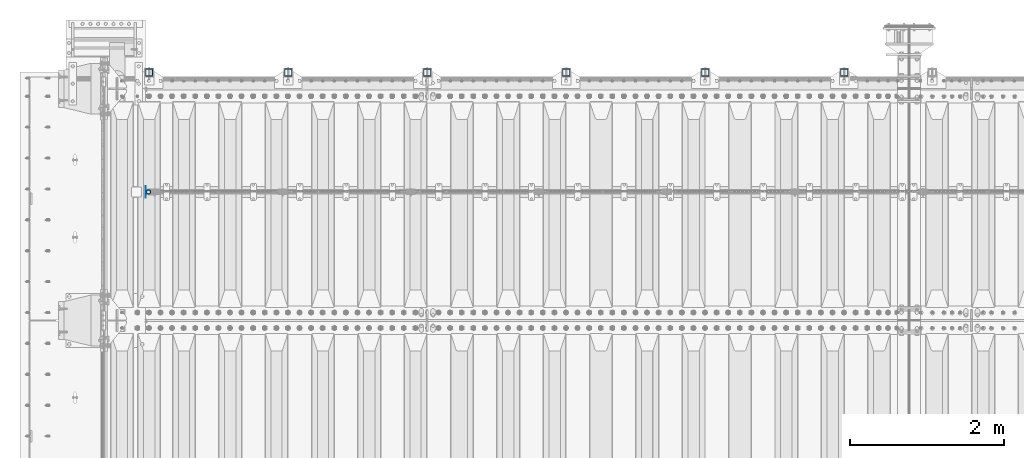
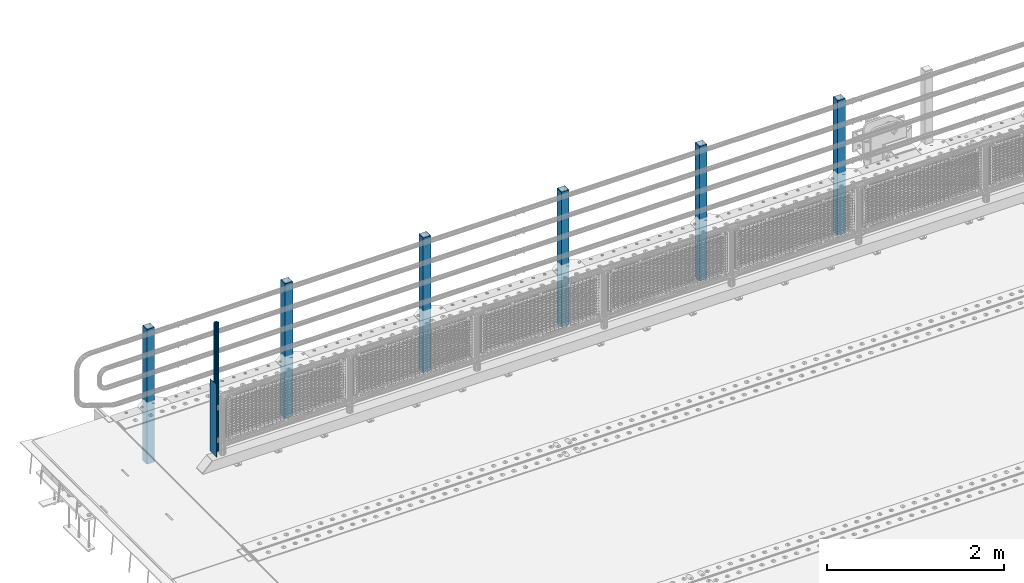
# One storey, part 60 of 219: 8 columns.
"""IFC2X3 building model written with IfcOpenShell, lengths in millimetres."""

from ifc_helpers import new_model, si_unit, frame, origin_with_axes, place, context, subcontext, project, spatial, faceted_brep, material, type_object, element, save


model = new_model("IFC2X3")

# Units and contexts
model_context = context("Model", 3, precision=1e-05, world=origin_with_axes())
body_context = subcontext(model_context, "Body", "Model", "MODEL_VIEW")
ifc_project = project(units=[si_unit("LENGTHUNIT", "METRE", prefix="MILLI"), si_unit("AREAUNIT", "SQUARE_METRE"), si_unit("VOLUMEUNIT", "CUBIC_METRE"), si_unit("MASSUNIT", "GRAM", prefix="KILO"), si_unit("TIMEUNIT", "SECOND"), si_unit("PLANEANGLEUNIT", "RADIAN"), si_unit("SOLIDANGLEUNIT", "STERADIAN"), si_unit("THERMODYNAMICTEMPERATUREUNIT", "DEGREE_CELSIUS"), si_unit("LUMINOUSINTENSITYUNIT", "LUMEN")], contexts=[model_context])

# Site, building, storey
site_placement = place(None, origin_with_axes())
site = spatial("IfcSite", under=ifc_project, at=site_placement, CompositionType="ELEMENT")
building_placement = place(site_placement, origin_with_axes())
building = spatial("IfcBuilding", under=site, at=building_placement, Name="Standard", CompositionType="ELEMENT")
storey_placement = place(building_placement, origin_with_axes())
storey = spatial("IfcBuildingStorey", under=building, at=storey_placement, Name="Undefined", CompositionType="ELEMENT", Elevation=0.0)

# Columns
ifc_material_1 = material(Name="Misc_Undefined")
column_type_1 = type_object("IfcColumnType", PredefinedType="NOTDEFINED")
column_1_placement = place(storey_placement, frame((541.0, 31664.5, 238.02), z_axis=(1.0, 0.0, 0.0), x_axis=(0.0, 0.0, 1.0)))
element("IfcColumn", 1, at=column_1_placement, inside=storey, type_object=column_type_1, material=ifc_material_1, context=body_context, shape_type="Brep", body=[
    faceted_brep([(0.0, -25.3499999999985, 0.0), (0.0, -23.4203461491597, 9.70102501045585), (1761.98, -23.4203461491597, 9.70102501045585), (1761.98, -25.3499999999985, 0.0), (0.0, -17.9251569030785, 17.9251569030785), (1761.98, -17.9251569030785, 17.9251569030785), (0.0, -9.70102501045403, 23.4203461491616), (1761.98, -9.70102501045403, 23.4203461491616), (0.0, 0.0, 25.3500000000004), (1761.98, 0.0, 25.3500000000004), (0.0, 9.70102501045403, 23.4203461491616), (1761.98, 9.70102501045403, 23.4203461491616), (0.0, 17.9251569030785, 17.9251569030785), (1761.98, 17.9251569030785, 17.9251569030785), (0.0, 23.4203461491597, 9.70102501045585), (1761.98, 23.4203461491597, 9.70102501045585), (0.0, 25.3499999999985, 0.0), (1761.98, 25.3499999999985, 0.0), (0.0, 23.4203461491597, -9.70102501045585), (1761.98, 23.4203461491597, -9.70102501045585), (0.0, 17.9251569030785, -17.9251569030785), (1761.98, 17.9251569030785, -17.9251569030785), (0.0, 9.70102501045403, -23.4203461491616), (1761.98, 9.70102501045403, -23.4203461491616), (0.0, 0.0, -25.3500000000004), (1761.98, 0.0, -25.3500000000004), (0.0, -9.70102501045403, -23.4203461491616), (1761.98, -9.70102501045403, -23.4203461491616), (0.0, -17.9251569030785, -17.9251569030785), (1761.98, -17.9251569030785, -17.9251569030785), (0.0, -23.4203461491597, -9.70102501045585), (1761.98, -23.4203461491597, -9.70102501045585), (0.0, -30.1500000000015, 0.0), (0.0, -27.8549679052157, -11.5379054858076), (1761.98, -27.8549679052157, -11.5379054858076), (1761.98, -30.1500000000015, 0.0), (0.0, -21.3192694527752, -21.3192694527752), (1761.98, -21.3192694527752, -21.3192694527752), (0.0, -11.5379054858058, -27.8549679052157), (1761.98, -11.5379054858058, -27.8549679052157), (0.0, 0.0, -30.1499999999996), (1761.98, 0.0, -30.1499999999996), (0.0, 11.5379054858058, -27.8549679052157), (1761.98, 11.5379054858058, -27.8549679052157), (0.0, 21.3192694527752, -21.3192694527752), (1761.98, 21.3192694527752, -21.3192694527752), (0.0, 27.8549679052157, -11.5379054858076), (1761.98, 27.8549679052157, -11.5379054858076), (0.0, 30.1500000000015, 0.0), (1761.98, 30.1500000000015, 0.0), (0.0, 27.8549679052157, 11.5379054858076), (1761.98, 27.8549679052157, 11.5379054858076), (0.0, 21.3192694527752, 21.3192694527752), (1761.98, 21.3192694527752, 21.3192694527752), (0.0, 11.5379054858058, 27.8549679052157), (1761.98, 11.5379054858058, 27.8549679052157), (0.0, 0.0, 30.1499999999996), (1761.98, 0.0, 30.1499999999996), (0.0, -11.5379054858058, 27.8549679052157), (1761.98, -11.5379054858058, 27.8549679052157), (0.0, -21.3192694527752, 21.3192694527752), (1761.98, -21.3192694527752, 21.3192694527752), (0.0, -27.8549679052157, 11.5379054858076), (1761.98, -27.8549679052157, 11.5379054858076)], [[[0, 1, 2, 3]], [[1, 4, 5, 2]], [[4, 6, 7, 5]], [[6, 8, 9, 7]], [[8, 10, 11, 9]], [[10, 12, 13, 11]], [[12, 14, 15, 13]], [[14, 16, 17, 15]], [[16, 18, 19, 17]], [[18, 20, 21, 19]], [[20, 22, 23, 21]], [[22, 24, 25, 23]], [[24, 26, 27, 25]], [[26, 28, 29, 27]], [[28, 30, 31, 29]], [[30, 0, 3, 31]], [[32, 33, 34, 35]], [[33, 36, 37, 34]], [[36, 38, 39, 37]], [[38, 40, 41, 39]], [[40, 42, 43, 41]], [[42, 44, 45, 43]], [[44, 46, 47, 45]], [[46, 48, 49, 47]], [[48, 50, 51, 49]], [[50, 52, 53, 51]], [[52, 54, 55, 53]], [[54, 56, 57, 55]], [[56, 58, 59, 57]], [[58, 60, 61, 59]], [[60, 62, 63, 61]], [[62, 32, 35, 63]], [[37, 39, 41, 43, 45, 47, 49, 51, 53, 55, 57, 59, 61, 63, 35, 34], [5, 7, 9, 11, 13, 15, 17, 19, 21, 23, 25, 27, 29, 31, 3, 2]], [[62, 60, 58, 56, 54, 52, 50, 48, 46, 44, 42, 40, 38, 36, 33, 32], [30, 28, 26, 24, 22, 20, 18, 16, 14, 12, 10, 8, 6, 4, 1, 0]]]),
])
column_type_2 = type_object("IfcColumnType", PredefinedType="NOTDEFINED")
column_2_placement = place(storey_placement, frame((504.5, 31664.5, 200.0), z_axis=(0.0, 1.0, 0.0), x_axis=(0.0, 0.0, 1.0)))
element("IfcColumn", 2, at=column_2_placement, inside=storey, type_object=column_type_2, material=ifc_material_1, context=body_context, shape_type="Brep", body=[
    faceted_brep([(0.0, 1.5, -75.0), (0.0, 1.5, 75.0), (1000.0, 1.5, 75.0), (1000.0, 1.5, -75.0), (0.0, -1.5, 75.0), (1000.0, -1.5, 75.0), (0.0, -1.5, -75.0), (1000.0, -1.5, -75.0)], [[[0, 1, 2, 3]], [[1, 4, 5, 2]], [[4, 6, 7, 5]], [[6, 0, 3, 7]], [[5, 7, 3, 2]], [[6, 4, 1, 0]]]),
])
ifc_material_2 = material()
column_type_3 = type_object("IfcColumnType", PredefinedType="NOTDEFINED")
for number, where, z_axis, x_axis in (
    (3, (9550.00000000013, 33210.0000000002, -844.999999999998), (0.0, -1.0, 0.0), (0.0, 0.0, 1.0)),
    (4, (7750.00000000013, 33210.0000000002, -844.999999999998), (0.0, -1.0, 0.0), (0.0, 0.0, 1.0)),
    (5, (5950.00000000013, 33210.0000000002, -844.999999999998), (0.0, -1.0, 0.0), (0.0, 0.0, 1.0)),
    (6, (4150.00000000013, 33210.0000000002, -844.999999999998), (0.0, -1.0, 0.0), (0.0, 0.0, 1.0)),
    (7, (2350.00000000013, 33210.0000000002, -844.999999999998), (0.0, -1.0, 0.0), (0.0, 0.0, 1.0)),
    (8, (550.000000000131, 33210.0000000002, -844.999999999998), (0.0, -1.0, 0.0), (0.0, 0.0, 1.0)),
):
    element("IfcColumn", number, at=place(storey_placement, frame(where, z_axis=z_axis, x_axis=x_axis)), inside=storey, type_object=column_type_3, material=ifc_material_2, context=body_context, shape_type="Brep", body=[
        faceted_brep([(0.0, 40.0, -40.0), (0.0, -40.0, -40.0), (1855.0, -40.0, -40.0), (1855.0, 40.0, -40.0), (0.0, -40.0, 40.0), (1855.0, -40.0, 40.0), (0.0, 40.0, 40.0), (1855.0, 40.0, 40.0), (0.0, 50.0, -50.0), (0.0, 50.0, 50.0), (1855.0, 50.0, 50.0), (1855.0, 50.0, -50.0), (0.0, -50.0, 50.0), (1855.0, -50.0, 50.0), (0.0, -50.0, -50.0), (1855.0, -50.0, -50.0)], [[[0, 1, 2, 3]], [[1, 4, 5, 2]], [[4, 6, 7, 5]], [[6, 0, 3, 7]], [[8, 9, 10, 11]], [[9, 12, 13, 10]], [[12, 14, 15, 13]], [[14, 8, 11, 15]], [[13, 15, 11, 10], [5, 7, 3, 2]], [[14, 12, 9, 8], [6, 4, 1, 0]]]),
    ])

save(model, "model.ifc")
